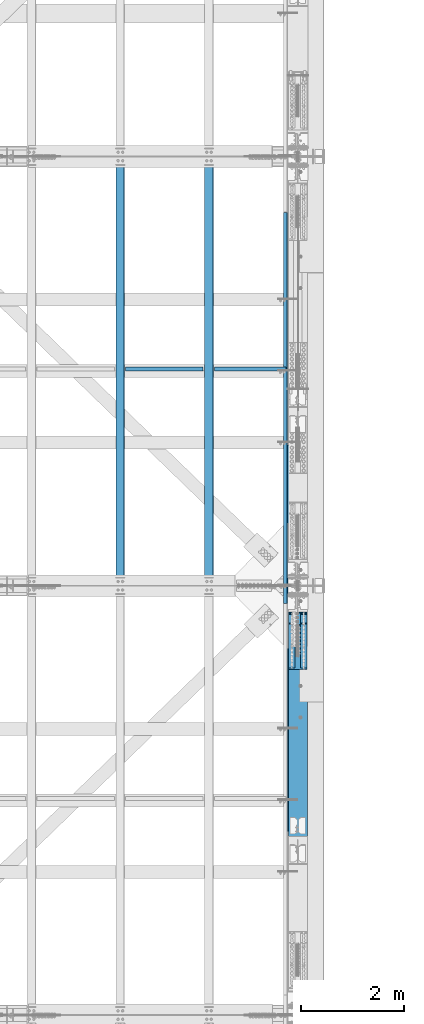
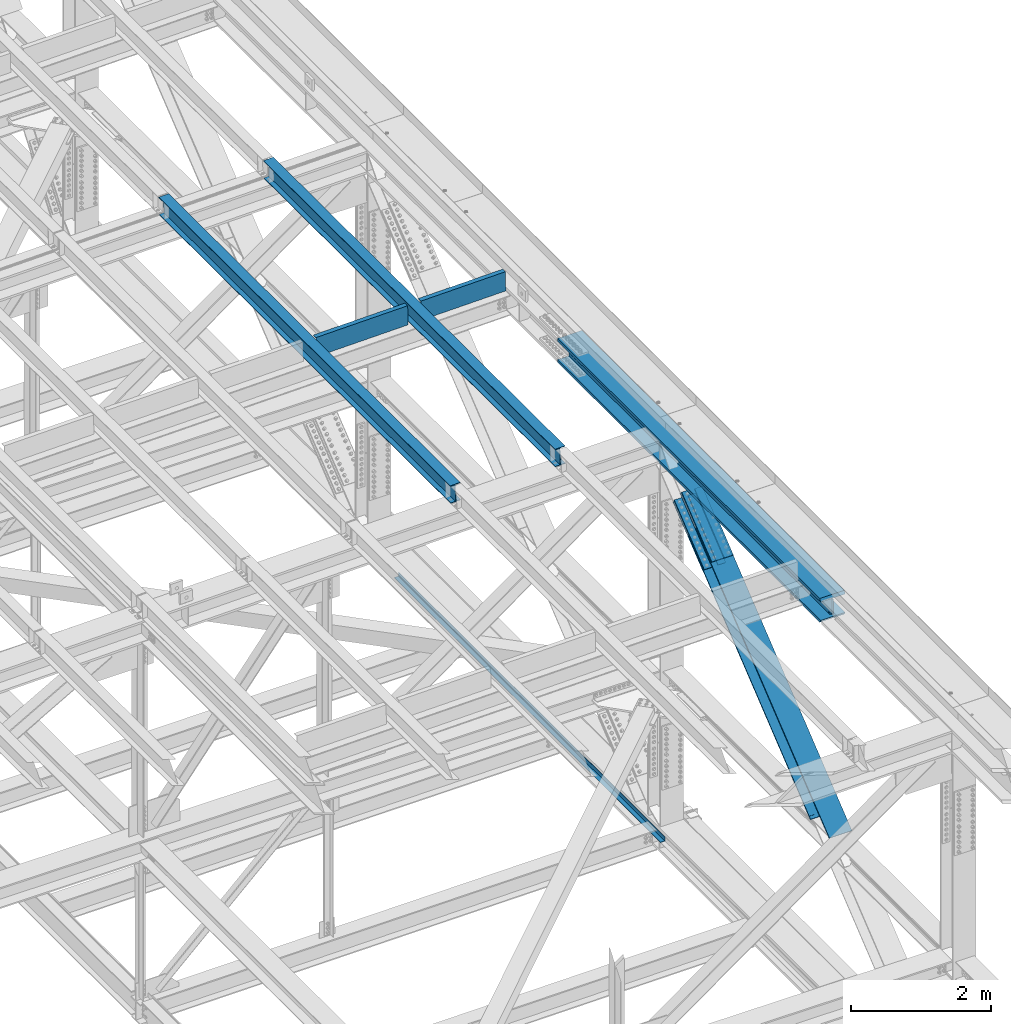
# One storey, part 1977 of 3843: 7 members, 6 beams, 7 elements without a shape of their own.
"""IFC2X3 building model written with IfcOpenShell, lengths in millimetres."""

from ifc_helpers import new_model, si_unit, frame, origin_with_axes, place, context, subcontext, project, spatial, faceted_brep, material, type_object, element, aggregate, save


model = new_model("IFC2X3")

# Units and contexts
model_context = context("Model", 3, precision=1e-05, world=origin_with_axes())
body_context = subcontext(model_context, "Body", "Model", "MODEL_VIEW")
ifc_project = project(units=[si_unit("LENGTHUNIT", "METRE", prefix="MILLI"), si_unit("AREAUNIT", "SQUARE_METRE"), si_unit("VOLUMEUNIT", "CUBIC_METRE"), si_unit("MASSUNIT", "GRAM", prefix="KILO"), si_unit("TIMEUNIT", "SECOND"), si_unit("PLANEANGLEUNIT", "RADIAN"), si_unit("SOLIDANGLEUNIT", "STERADIAN"), si_unit("THERMODYNAMICTEMPERATUREUNIT", "DEGREE_CELSIUS"), si_unit("LUMINOUSINTENSITYUNIT", "LUMEN")], contexts=[model_context])

# Site, building, storey
site_placement = place(None, origin_with_axes())
site = spatial("IfcSite", under=ifc_project, at=site_placement, CompositionType="ELEMENT")
building_placement = place(site_placement, origin_with_axes())
building = spatial("IfcBuilding", under=site, at=building_placement, Name="Undefined", CompositionType="ELEMENT")
storey_placement = place(building_placement, origin_with_axes())
storey = spatial("IfcBuildingStorey", under=building, at=storey_placement, Name="Undefined", CompositionType="ELEMENT", Elevation=0.0)

# Assembly, beam
assembly_1_placement = place(storey_placement, origin_with_axes())
assembly_1 = element("IfcElementAssembly", 1, at=assembly_1_placement, inside=storey, Name="BEAM", AssemblyPlace="NOTDEFINED", PredefinedType="RIGID_FRAME")
ifc_material_1 = material(Name="STEEL/A992")
beam_type_1 = type_object("IfcBeamType", Name="W12X26", PredefinedType="NOTDEFINED")
beam_1_placement = place(assembly_1_placement, frame((83918.3094465648, 67272.2298498019, 46651.1662682145), z_axis=(-0.0211520976180764, 0.00212019800049893, 0.999774021230195), x_axis=(-2.19999993850589e-08, 0.999997751370484, -0.00212067300078588)))
beam_1 = element("IfcBeam", 2, at=beam_1_placement, type_object=beam_type_1, material=ifc_material_1, Name="BEAM", ObjectType="W12X26", context=body_context, shape_type="Brep", body=[
    faceted_brep([(12.7037333159387, 82.5499999998865, -155.574999999728), (12.6835383837752, 82.5499999999302, -146.049999999741), (8343.90227212172, 82.5500000208849, -146.050000006406), (8343.92246705385, 82.5500000208558, -155.575000006393), (12.6799761301809, 3.17499999947904, -146.049999999777), (8343.8987098681, 3.17500002044835, -146.050000006442), (12.0606648778776, 3.17500000054133, 146.049999999763), (8343.27939861581, 3.17500002149609, 146.049999993105), (12.0642271314864, 82.5500000009924, 146.049999999799), (8343.28296086943, 82.5500000219472, 146.049999993134), (12.0440321993519, 82.5500000010361, 155.574999999786), (8343.2627659373, 82.5500000219763, 155.574999993121), (12.0366227118211, -82.5499999998865, 155.574999999699), (8343.25535644976, -82.5499999789463, 155.574999993041), (12.0568176439701, -82.5499999999156, 146.049999999719), (8343.27555138191, -82.5499999789899, 146.049999993054), (12.060379897579, -3.17499999947904, 146.049999999748), (8343.27911363552, -3.17499997852428, 146.049999993098), (12.6796911498823, -3.17500000055588, -146.049999999785), (8343.89841171799, -3.17499999977736, -146.04999998711), (12.6761288962589, -82.5500000009924, -146.049999999828), (8343.8948483616, -82.550000000876, -146.049999972267), (12.6963238284079, -82.5500000010215, -155.574999999808), (8343.91505756634, -82.5499999800668, -155.575000006465)], [[[0, 1, 2, 3]], [[1, 4, 5, 2]], [[4, 6, 7, 5]], [[6, 8, 9, 7]], [[8, 10, 11, 9]], [[10, 12, 13, 11]], [[12, 14, 15, 13]], [[14, 16, 17, 15]], [[16, 18, 19, 17]], [[18, 20, 21, 19]], [[20, 22, 23, 21]], [[22, 0, 3, 23]], [[5, 7, 9, 11, 13, 15, 17, 19, 21, 23, 3, 2]], [[22, 20, 18, 16, 14, 12, 10, 8, 6, 4, 1, 0]]]),
])
aggregate(assembly_1, [beam_1])

assembly_2_placement = place(storey_placement, origin_with_axes())
assembly_2 = element("IfcElementAssembly", 3, at=assembly_2_placement, inside=storey, Name="BEAM", AssemblyPlace="NOTDEFINED", PredefinedType="RIGID_FRAME")
beam_2_placement = place(assembly_2_placement, frame((82191.1094465142, 67272.2332875575, 46619.343604067), z_axis=(-0.0211520976140747, 0.00214229500025977, 0.99977397412548), x_axis=(-2.20000000902242e-08, 0.999997704255013, -0.00214277500054673)))
beam_2 = element("IfcBeam", 4, at=beam_2_placement, type_object=beam_type_1, material=ifc_material_1, Name="BEAM", ObjectType="W12X26", context=body_context, shape_type="Brep", body=[
    faceted_brep([(12.7037963889888, 82.550000000585, -155.57500000039), (12.68336709289, 82.5499999996246, -146.050000000039), (8343.90246569729, 82.5499999989333, -146.049999980707), (8343.92289895112, 82.5500000208558, -155.575000023666), (12.6797677313734, 3.17499999917345, -146.049999999879), (8343.89889418155, 3.1750000204629, -146.050000023519), (12.0540018845641, 3.17500000089058, 146.04999999977), (8343.27312833472, 3.17500002216548, 146.049999976145), (12.057601246066, 82.5500000013271, 146.04999999961), (8343.27672769624, 82.5500000226166, 146.049999975985), (12.0371958380274, 82.5500000013853, 155.574999999597), (8343.2563222882, 82.5500000226748, 155.574999975972), (12.0297091660614, -82.5499999995372, 155.574999999932), (8343.24883561624, -82.5499999782623, 155.574999976292), (12.0501145741, -82.5499999995955, 146.049999999945), (8343.26924102426, -82.549999978306, 146.049999976312), (12.0537139356311, -3.1749999991589, 146.049999999785), (8343.27284038581, -3.17499997786945, 146.049999976145), (12.679479782455, -3.17500000086147, -146.049999999857), (8343.89860623263, -3.17499997957202, -146.050000023497), (12.6758804209385, -82.550000001298, -146.049999999705), (8343.89500687108, -82.5499999800086, -146.050000023337), (12.6962628250476, -82.5500000003522, -155.574999999924), (8343.91541227915, -82.5499999800668, -155.575000023331)], [[[0, 1, 2, 3]], [[1, 4, 5, 2]], [[4, 6, 7, 5]], [[6, 8, 9, 7]], [[8, 10, 11, 9]], [[10, 12, 13, 11]], [[12, 14, 15, 13]], [[14, 16, 17, 15]], [[16, 18, 19, 17]], [[18, 20, 21, 19]], [[20, 22, 23, 21]], [[22, 0, 3, 23]], [[5, 7, 9, 11, 13, 15, 17, 19, 21, 23, 3, 2]], [[22, 20, 18, 16, 14, 12, 10, 8, 6, 4, 1, 0]]]),
])
aggregate(assembly_2, [beam_2])

assembly_3_placement = place(storey_placement, origin_with_axes())
assembly_3 = element("IfcElementAssembly", 5, at=assembly_3_placement, inside=storey, Name="BENT_PLATE", AssemblyPlace="NOTDEFINED", PredefinedType="RIGID_FRAME")
ifc_material_2 = material(Name="STEEL/A36")
beam_type_2 = type_object("IfcBeamType", PredefinedType="NOTDEFINED")
beam_3_placement = place(assembly_3_placement, frame((83058.4218909603, 71454.9625000037, 46442.2912357653), z_axis=(-0.999843950547446, 0.0, -0.0176656319920002), x_axis=(-0.0176656319919986, 0.0, 0.999843950547446)))
beam_3 = element("IfcBeam", 6, at=beam_3_placement, type_object=beam_type_2, material=ifc_material_2, Name="BENT_PLATE", context=body_context, shape_type="Brep", body=[
    faceted_brep([(2.38651409745216e-09, -4.76249999999709, -755.649999997448), (-2.37923813983798e-09, -4.76249999999709, 755.649999997433), (-2.37923813983798e-09, 4.76249999999709, 755.649999997433), (2.38651409745216e-09, 4.76249999999709, -755.649999997448), (327.024999945941, 4.76250000002619, 755.650000004171), (327.024999981295, 4.76250000002619, -755.650000004418), (336.549999981282, -4.76249999996799, -755.650000004447), (336.549999945928, -4.76249999996799, 755.650000004156), (327.024999958514, 71.4375000207219, 755.650000005364), (327.024999968708, 71.4375000458094, -755.650000003239), (336.549999958501, 71.4375000207219, 755.650000005349), (336.549999968687, 71.4375000458094, -755.650000003254)], [[[0, 1, 2, 3]], [[3, 2, 4, 5]], [[1, 0, 6, 7]], [[5, 4, 8, 9]], [[4, 2, 1, 7, 10, 8]], [[7, 6, 11, 10]], [[6, 0, 3, 5, 9, 11]], [[10, 11, 9, 8]]]),
])
aggregate(assembly_3, [beam_3])

assembly_4_placement = place(storey_placement, origin_with_axes())
assembly_4 = element("IfcElementAssembly", 7, at=assembly_4_placement, inside=storey, Name="BENT_PLATE", AssemblyPlace="NOTDEFINED", PredefinedType="RIGID_FRAME")
beam_4_placement = place(assembly_4_placement, frame((84728.2827694122, 71454.9625000034, 46471.6545374752), z_axis=(-0.999843928690838, 0.0, -0.0176668689945436), x_axis=(-0.0176668689945437, 0.0, 0.999843928690838)))
beam_4 = element("IfcBeam", 8, at=beam_4_placement, type_object=beam_type_2, material=ifc_material_2, Name="BENT_PLATE", context=body_context, shape_type="Brep", body=[
    faceted_brep([(2.20461515709758e-09, -4.76249999999709, -698.499999997657), (-2.19733919948339e-09, -4.76249999999709, 698.499999997628), (-2.19733919948339e-09, 4.76249999999709, 698.499999997628), (2.20461515709758e-09, 4.76249999999709, -698.499999997657), (327.025000023619, 4.76250000002619, 698.499999999302), (327.025000025125, 4.76250000002619, -698.50000000326), (336.550000025134, -4.76249999996799, -698.500000003318), (336.550000023642, -4.76249999996799, 698.499999999243), (327.025000023437, 71.4374999717184, 698.499999999287), (327.025000025285, 71.4374999714419, -698.500000003274), (336.550000023461, 71.4374999717184, 698.499999999229), (336.550000025301, 71.4374999714419, -698.500000003332)], [[[0, 1, 2, 3]], [[3, 2, 4, 5]], [[1, 0, 6, 7]], [[5, 4, 8, 9]], [[4, 2, 1, 7, 10, 8]], [[7, 6, 11, 10]], [[6, 0, 3, 5, 9, 11]], [[10, 11, 9, 8]]]),
])
aggregate(assembly_4, [beam_4])

# Assembly, beam, members
assembly_5_placement = place(storey_placement, origin_with_axes())
assembly_5 = element("IfcElementAssembly", 9, at=assembly_5_placement, inside=storey, Name="BEAM", AssemblyPlace="NOTDEFINED", PredefinedType="RIGID_FRAME")
beam_type_3 = type_object("IfcBeamType", Name="W14X257", PredefinedType="NOTDEFINED")
beam_5_placement = place(assembly_5_placement, frame((85648.8, 62483.8773032231, 46323.7310074759), z_axis=(0.0, 0.00121918199975334, 0.99999925679735), x_axis=(0.0, 0.99999925679735, -0.00121918199975249)))
beam_5 = element("IfcBeam", 10, at=beam_5_placement, type_object=beam_type_3, material=ifc_material_1, Name="BEAM", ObjectType="W14X257", context=body_context, shape_type="Brep", body=[
    faceted_brep([(4.78626660341979, 15.0812500000029, -125.806809621186), (22.248763224532, -15.0812500000029, -125.795470890975), (22.1322069293601, -15.0812500000029, 125.818679072472), (4.66970807439066, 15.0812500000029, 125.812162637063), (31.811818305905, 203.199999999997, -207.944518907141), (31.811818305905, -203.199999999997, -207.944518907141), (4.80226115437108, -203.199999999997, -160.334806021325), (4.80226115437108, -15.0812500000029, -160.334806021325), (4.80226115437108, 15.0812500000029, -160.334806021325), (4.80226115437108, 203.199999999997, -160.334806021325), (31.619153337313, -203.199999999997, 207.979925171952), (31.6191421760959, 203.199999999997, 207.980437848382), (4.65371352270449, 203.199999999997, 160.340160639891), (4.65371352270449, 15.0812500000029, 160.340160639891), (4.65371352270449, -15.0812500000029, 160.340160639891), (4.65371352270449, -203.199999999997, 160.340160639891), (99.001969869656, 15.0812500000029, -125.745633578335), (99.001969869656, -15.0812500000029, -125.745633578335), (103.853059904824, 15.0812500000029, -127.069868396189), (103.853059904824, -15.0812500000029, -127.069868396189), (107.353797789598, 15.0812500000029, -130.679786213004), (107.353797789598, -15.0812500000029, -130.679786213004), (70.8577501062537, -15.0812500000029, -160.297400892843), (70.8577501062537, 15.0812500000029, -160.297400892843), (103.329591465474, -15.0812500000029, -143.758905525203), (103.329591465474, 15.0812500000029, -143.758905525203), (107.049682716461, -15.0812500000029, -140.375476278648), (107.049682716461, 15.0812500000029, -140.375476278648), (108.528472206723, -15.0812500000029, -135.569245528299), (108.528472206723, 15.0812500000029, -135.569245528299), (753.188996009027, -203.199999999997, -207.536025889502), (753.188996009027, 203.199999999997, -207.536025889502), (1506.24719244146, 203.199999999997, -207.204355812879), (1506.24719244146, -203.199999999997, -207.204355812879), (2259.30542464805, 203.199999999997, -206.967448611089), (2259.30542464805, -203.199999999997, -206.967448611089), (3012.36368070407, 203.199999999997, -206.825304288774), (3012.36368070407, -203.199999999997, -206.825304288774), (3765.42194868479, 203.199999999997, -206.777922846879), (3765.42194868479, -203.199999999997, -206.777922846879), (4518.48021666553, 203.199999999997, -206.825304287253), (4518.48021666553, -203.199999999997, -206.825304287253), (5271.53847272154, 203.199999999997, -206.967448608062), (5271.53847272154, -203.199999999997, -206.967448608062), (6024.59670492813, 203.199999999997, -207.204355808346), (6024.59670492813, -203.199999999997, -207.204355808346), (6777.65490136057, 203.199999999997, -207.536025883455), (6777.65490136057, -203.199999999997, -207.536025883455), (7524.36043722983, 203.199999999997, -207.958861545558), (7524.36043722983, -203.199999999997, -207.958861545558), (7524.39070171332, -203.199999999997, -160.333871141935), (6777.67887338098, -203.199999999997, -159.911031916607), (6024.61468394376, -203.199999999997, -159.579359201998), (5271.55045873209, -203.199999999997, -159.342450116346), (4518.48620967082, -203.199999999997, -159.200304664329), (3765.42194868474, -203.199999999997, -159.152922846879), (3012.35768769867, -203.199999999997, -159.200304665843), (2259.2934386374, -203.199999999997, -159.34245011938), (1506.22921342575, -203.199999999997, -159.579359206524), (753.165023988513, -203.199999999997, -159.911031922653), (70.8577501062537, -203.199999999997, -160.297400892843), (70.8577501062537, 203.199999999997, -160.297400892843), (753.165023988513, 203.199999999997, -159.911031922653), (1506.22921342575, 203.199999999997, -159.579359206524), (2259.2934386374, 203.199999999997, -159.34245011938), (3012.35768769867, 203.199999999997, -159.200304665843), (3765.42194868474, 203.199999999997, -159.152922846879), (4518.48620967082, 203.199999999997, -159.200304664329), (5271.55045873209, 203.199999999997, -159.342450116346), (6024.61468394376, 203.199999999997, -159.579359201998), (6777.67887338098, 203.199999999997, -159.911031916607), (7524.39070171332, 203.199999999997, -160.333871141935), (753.165023988513, 15.0812500000029, -159.911031922653), (1506.22921342575, 15.0812500000029, -159.579359206524), (2259.2934386374, 15.0812500000029, -159.34245011938), (3012.35768769867, 15.0812500000029, -159.200304665843), (3765.42194868474, 15.0812500000029, -159.152922846879), (4518.48620967082, 15.0812500000029, -159.200304664329), (5271.55045873209, 15.0812500000029, -159.342450116346), (6024.61468394376, 15.0812500000029, -159.579359201998), (6777.67887338098, 15.0812500000029, -159.911031916607), (7524.39070171332, 15.0812500000029, -160.333871141935), (6777.84028498505, -203.199999999997, 160.763927460146), (6777.84028498505, -15.0812500000029, 160.763927460146), (7524.59448256891, -15.0812500000029, 160.341064242457), (7524.59448256891, -203.199999999997, 160.341064242457), (6024.73574264898, -203.199999999997, 161.095617947423), (6024.73574264898, -15.0812500000029, 161.095617947423), (5271.63116453652, -203.199999999997, 161.332539727831), (5271.63116453652, -15.0812500000029, 161.332539727831), (4518.5265625732, -203.199999999997, 161.474692796699), (4518.5265625732, -15.0812500000029, 161.474692796699), (3765.42194868442, -203.199999999997, 161.522077153109), (3765.42194868442, -15.0812500000029, 161.522077153109), (3012.31733479565, -203.199999999997, 161.474692795186), (3012.31733479565, -15.0812500000029, 161.474692795186), (2259.21273283232, -203.199999999997, 161.332539724812), (2259.21273283232, -15.0812500000029, 161.332539724812), (1506.10815471988, -203.199999999997, 161.09561794289), (1506.10815471988, -15.0812500000029, 161.09561794289), (753.003612383793, -203.199999999997, 160.7639274541), (753.003612383793, -15.0812500000029, 160.7639274541), (70.6906636784406, -15.0812500000029, 160.377555270432), (70.6906636784406, -203.199999999997, 160.377555270432), (752.979640363294, -203.199999999997, 208.388921420948), (752.979640363294, 203.199999999997, 208.388921420948), (1506.09017570417, -203.199999999997, 208.720614549246), (1506.09017570417, 203.199999999997, 208.720614549246), (2259.20074682168, -203.199999999997, 208.957538216513), (2259.20074682168, 203.199999999997, 208.957538216513), (3012.31134179025, -203.199999999997, 209.099692418116), (3012.31134179025, 203.199999999997, 209.099692418116), (3765.42194868436, -203.199999999997, 209.147077153109), (3765.42194868436, 203.199999999997, 209.147077153109), (4518.53255557851, -203.199999999997, 209.099692419622), (4518.53255557851, 203.199999999997, 209.099692419622), (5271.64315054708, -203.199999999997, 208.95753821954), (5271.64315054708, 203.199999999997, 208.95753821954), (6024.75372166459, -203.199999999997, 208.720614553778), (6024.75372166459, 203.199999999997, 208.720614553778), (6777.86425700548, -203.199999999997, 208.388921426995), (6777.86425700548, 203.199999999997, 208.388921426995), (7524.62474705241, -203.199999999997, 207.96605464608), (7524.62474705241, 203.199999999997, 207.96605464608), (7524.59448256891, 203.199999999997, 160.341064242457), (6777.84028498505, 203.199999999997, 160.763927460146), (6024.73574264898, 203.199999999997, 161.095617947423), (5271.63116453652, 203.199999999997, 161.332539727831), (4518.5265625732, 203.199999999997, 161.474692796699), (3765.42194868442, 203.199999999997, 161.522077153109), (3012.31733479565, 203.199999999997, 161.474692795186), (2259.21273283232, 203.199999999997, 161.332539724812), (1506.10815471988, 203.199999999997, 161.09561794289), (753.003612383793, 203.199999999997, 160.7639274541), (70.6906636784406, 203.199999999997, 160.377555270432), (6777.84028498505, 15.0812500000029, 160.763927460146), (7524.59448256891, 15.0812500000029, 160.341064242457), (6024.73574264898, 15.0812500000029, 161.095617947423), (5271.63116453652, 15.0812500000029, 161.332539727831), (4518.5265625732, 15.0812500000029, 161.474692796699), (3765.42194868442, 15.0812500000029, 161.522077153109), (3012.31733479565, 15.0812500000029, 161.474692795186), (2259.21273283232, 15.0812500000029, 161.332539724812), (1506.10815471988, 15.0812500000029, 161.09561794289), (753.003612383793, 15.0812500000029, 160.7639274541), (70.6906636784406, 15.0812500000029, 160.377555270432), (98.8702027578183, -15.0812500000029, 125.847315191349), (98.8702027578183, 15.0812500000029, 125.847315191349), (103.719936227862, -15.0812500000029, 127.176509553086), (103.719936227862, 15.0812500000029, 127.176509553086), (107.216981144185, -15.0812500000029, 130.790004984796), (107.216981144185, 15.0812500000029, 130.790004984796), (108.386655478542, -15.0812500000029, 135.68066284783), (108.386655478542, 15.0812500000029, 135.68066284783), (106.902952393793, -15.0812500000029, 140.485379024467), (106.902952393793, 15.0812500000029, 140.485379024467), (103.179403533504, -15.0812500000029, 143.865002711631), (103.179403533504, 15.0812500000029, 143.865002711631), (7524.39070171332, -15.0812500000029, -160.333871141935), (6777.67887338098, -15.0812500000029, -159.911031916607), (6024.61468394376, -15.0812500000029, -159.579359201998), (5271.55045873209, -15.0812500000029, -159.342450116346), (4518.48620967082, -15.0812500000029, -159.200304664329), (3765.42194868474, -15.0812500000029, -159.152922846879), (3012.35768769867, -15.0812500000029, -159.200304665843), (2259.2934386374, -15.0812500000029, -159.34245011938), (1506.22921342575, -15.0812500000029, -159.579359206524), (753.165023988513, -15.0812500000029, -159.911031922653)], [[[0, 1, 2, 3]], [[4, 5, 6, 7, 8, 9]], [[10, 11, 12, 13, 14, 15]], [[16, 17, 1, 0]], [[17, 16, 18, 19]], [[19, 18, 20, 21]], [[22, 23, 8, 7]], [[24, 25, 23, 22]], [[26, 27, 25, 24]], [[28, 29, 27, 26]], [[21, 20, 29, 28]], [[30, 31, 32, 33]], [[33, 32, 34, 35]], [[35, 34, 36, 37]], [[37, 36, 38, 39]], [[39, 38, 40, 41]], [[41, 40, 42, 43]], [[43, 42, 44, 45]], [[45, 44, 46, 47]], [[47, 46, 48, 49]], [[30, 33, 35, 37, 39, 41, 43, 45, 47, 49, 50, 51, 52, 53, 54, 55, 56, 57, 58, 59, 60, 6, 5]], [[31, 30, 5, 4]], [[61, 62, 63, 64, 65, 66, 67, 68, 69, 70, 71, 48, 46, 44, 42, 40, 38, 36, 34, 32, 31, 4, 9]], [[62, 72, 73, 63]], [[63, 73, 74, 64]], [[64, 74, 75, 65]], [[65, 75, 76, 66]], [[66, 76, 77, 67]], [[67, 77, 78, 68]], [[68, 78, 79, 69]], [[69, 79, 80, 70]], [[70, 80, 81, 71]], [[82, 83, 84, 85]], [[86, 87, 83, 82]], [[88, 89, 87, 86]], [[90, 91, 89, 88]], [[92, 93, 91, 90]], [[94, 95, 93, 92]], [[96, 97, 95, 94]], [[98, 99, 97, 96]], [[100, 101, 99, 98]], [[102, 101, 100, 103, 15, 14]], [[104, 105, 11, 10]], [[105, 104, 106, 107]], [[107, 106, 108, 109]], [[109, 108, 110, 111]], [[111, 110, 112, 113]], [[113, 112, 114, 115]], [[115, 114, 116, 117]], [[117, 116, 118, 119]], [[119, 118, 120, 121]], [[121, 120, 122, 123]], [[105, 107, 109, 111, 113, 115, 117, 119, 121, 123, 124, 125, 126, 127, 128, 129, 130, 131, 132, 133, 134, 12, 11]], [[135, 125, 124, 136]], [[137, 126, 125, 135]], [[138, 127, 126, 137]], [[139, 128, 127, 138]], [[140, 129, 128, 139]], [[141, 130, 129, 140]], [[142, 131, 130, 141]], [[143, 132, 131, 142]], [[144, 133, 132, 143]], [[134, 133, 144, 145, 13, 12]], [[146, 147, 3, 2]], [[148, 149, 147, 146]], [[150, 151, 149, 148]], [[152, 153, 151, 150]], [[154, 155, 153, 152]], [[156, 157, 155, 154]], [[102, 145, 157, 156]], [[14, 13, 145, 102]], [[103, 100, 98, 96, 94, 92, 90, 88, 86, 82, 85, 122, 120, 118, 116, 114, 112, 110, 108, 106, 104, 10, 15]], [[84, 158, 50, 49, 48, 71, 81, 136, 124, 123, 122, 85]], [[159, 51, 50, 158]], [[160, 52, 51, 159]], [[161, 53, 52, 160]], [[162, 54, 53, 161]], [[163, 55, 54, 162]], [[164, 56, 55, 163]], [[165, 57, 56, 164]], [[166, 58, 57, 165]], [[167, 59, 58, 166]], [[60, 59, 167, 22, 7, 6]], [[23, 72, 62, 61, 9, 8]], [[18, 16, 0, 3, 147, 149, 151, 153, 155, 157, 145, 144, 143, 142, 141, 140, 139, 138, 137, 135, 136, 81, 80, 79, 78, 77, 76, 75, 74, 73, 72, 23, 25, 27, 29, 20]], [[17, 19, 21, 28, 26, 24, 22, 167, 166, 165, 164, 163, 162, 161, 160, 159, 158, 84, 83, 87, 89, 91, 93, 95, 97, 99, 101, 102, 156, 154, 152, 150, 148, 146, 2, 1]]]),
])
ifc_material_3 = material(Name="STEEL/A572-50")
member_type_1 = type_object("IfcMemberType", PredefinedType="NOTDEFINED")
member_1_placement = place(assembly_5_placement, frame((85763.1, 65864.6813905742, 44989.4552590053), z_axis=(-1.0, 0.0, 0.0), x_axis=(0.0, 0.77717665715686, 0.629282483127005)))
member_1 = element("IfcMember", 11, at=member_1_placement, type_object=member_type_1, material=ifc_material_3, Name="PLATE", context=body_context, shape_type="Brep", body=[
    faceted_brep([(-4.36557456851006e-11, 12.7000000000116, -63.5), (-4.36557456851006e-11, 12.7000000000116, 63.5), (1104.90000001677, 12.7000000017251, 63.5), (1104.90000001677, 12.7000000017251, -63.5), (1.45519152283669e-11, -12.700000000008, 63.5), (1104.90000001682, -12.6999999982909, 63.5), (1.45519152283669e-11, -12.700000000008, -63.5), (1104.90000001682, -12.6999999982909, -63.5)], [[[0, 1, 2, 3]], [[1, 4, 5, 2]], [[4, 6, 7, 5]], [[6, 0, 3, 7]], [[5, 7, 3, 2]], [[6, 4, 1, 0]]]),
])
member_2_placement = place(assembly_5_placement, frame((85763.1, 65678.8700053605, 45218.9360964451), z_axis=(-1.0, 0.0, 0.0), x_axis=(0.0, 0.77717665715686, 0.629282483127005)))
member_2 = element("IfcMember", 12, at=member_2_placement, type_object=member_type_1, material=ifc_material_3, Name="PLATE", context=body_context, shape_type="Brep", body=[
    faceted_brep([(-4.36557456851006e-11, 12.7000000000116, -63.5), (-4.36557456851006e-11, 12.7000000000116, 63.5), (1104.90000001677, 12.7000000017251, 63.5), (1104.90000001677, 12.7000000017251, -63.5), (1.45519152283669e-11, -12.700000000008, 63.5), (1104.90000001682, -12.6999999982909, 63.5), (1.45519152283669e-11, -12.700000000008, -63.5), (1104.90000001682, -12.6999999982909, -63.5)], [[[0, 1, 2, 3]], [[1, 4, 5, 2]], [[4, 6, 7, 5]], [[6, 0, 3, 7]], [[5, 7, 3, 2]], [[6, 4, 1, 0]]]),
])
member_3_placement = place(assembly_5_placement, frame((85534.5, 65864.6813905742, 44989.4552590053), z_axis=(-1.0, 0.0, 0.0), x_axis=(0.0, 0.77717665715686, 0.629282483127005)))
member_3 = element("IfcMember", 13, at=member_3_placement, type_object=member_type_1, material=ifc_material_3, Name="PLATE", context=body_context, shape_type="Brep", body=[
    faceted_brep([(-4.36557456851006e-11, 12.7000000000116, -63.5), (-4.36557456851006e-11, 12.7000000000116, 63.5), (1104.90000001677, 12.7000000017251, 63.5), (1104.90000001677, 12.7000000017251, -63.5), (1.45519152283669e-11, -12.700000000008, 63.5), (1104.90000001682, -12.6999999982909, 63.5), (1.45519152283669e-11, -12.700000000008, -63.5), (1104.90000001682, -12.6999999982909, -63.5)], [[[0, 1, 2, 3]], [[1, 4, 5, 2]], [[4, 6, 7, 5]], [[6, 0, 3, 7]], [[5, 7, 3, 2]], [[6, 4, 1, 0]]]),
])
member_4_placement = place(assembly_5_placement, frame((85534.5, 65678.8700067443, 45218.9360947362), z_axis=(-1.0, 0.0, 0.0), x_axis=(0.0, 0.77717665715686, 0.629282483127005)))
member_4 = element("IfcMember", 14, at=member_4_placement, type_object=member_type_1, material=ifc_material_3, Name="PLATE", context=body_context, shape_type="Brep", body=[
    faceted_brep([(-4.36557456851006e-11, 12.7000000000116, -63.5), (-4.36557456851006e-11, 12.7000000000116, 63.5), (1104.90000001677, 12.7000000017251, 63.5), (1104.90000001677, 12.7000000017251, -63.5), (1.45519152283669e-11, -12.700000000008, 63.5), (1104.90000001682, -12.6999999982909, 63.5), (1.45519152283669e-11, -12.700000000008, -63.5), (1104.90000001682, -12.6999999982909, -63.5)], [[[0, 1, 2, 3]], [[1, 4, 5, 2]], [[4, 6, 7, 5]], [[6, 0, 3, 7]], [[5, 7, 3, 2]], [[6, 4, 1, 0]]]),
])
member_type_2 = type_object("IfcMemberType", PredefinedType="NOTDEFINED")
member_5_placement = place(assembly_5_placement, frame((85648.8, 66751.3554868311, 45650.2039704377), z_axis=(-1.0, 0.0, 0.0), x_axis=(0.0, -0.77717665715686, -0.629282483127005)))
member_5 = element("IfcMember", 15, at=member_5_placement, type_object=member_type_2, material=ifc_material_3, Name="PLATE", context=body_context, shape_type="Brep", body=[
    faceted_brep([(-1.45519152283669e-11, 12.7000000000025, -177.800000000003), (-1.45519152283669e-11, 12.7000000000025, 177.800000000003), (1104.90000001682, 12.7000000017051, 177.800000000003), (1104.90000001682, 12.7000000017051, -177.800000000003), (4.36557456851006e-11, -12.7000000000171, 177.800000000003), (1104.90000001686, -12.6999999983072, 177.800000000003), (4.36557456851006e-11, -12.7000000000171, -177.800000000003), (1104.90000001686, -12.6999999983072, -177.800000000003)], [[[0, 1, 2, 3]], [[1, 4, 5, 2]], [[4, 6, 7, 5]], [[6, 0, 3, 7]], [[5, 7, 3, 2]], [[6, 4, 1, 0]]]),
])
member_6_placement = place(assembly_5_placement, frame((85648.8, 66509.6008874657, 45948.7758144295), z_axis=(-1.0, 0.0, 0.0), x_axis=(0.0, -0.77717665715686, -0.629282483127005)))
member_6 = element("IfcMember", 16, at=member_6_placement, type_object=member_type_2, material=ifc_material_3, Name="PLATE", context=body_context, shape_type="Brep", body=[
    faceted_brep([(-1.45519152283669e-11, 12.7000000000025, -177.800000000003), (-1.45519152283669e-11, 12.7000000000025, 177.800000000003), (1104.90000001682, 12.7000000017051, 177.800000000003), (1104.90000001682, 12.7000000017051, -177.800000000003), (4.36557456851006e-11, -12.7000000000171, 177.800000000003), (1104.90000001686, -12.6999999983072, 177.800000000003), (4.36557456851006e-11, -12.7000000000171, -177.800000000003), (1104.90000001686, -12.6999999983072, -177.800000000003)], [[[0, 1, 2, 3]], [[1, 4, 5, 2]], [[4, 6, 7, 5]], [[6, 0, 3, 7]], [[5, 7, 3, 2]], [[6, 4, 1, 0]]]),
])
aggregate(assembly_5, [beam_5, member_1, member_2, member_3, member_4, member_5, member_6])

# Assembly, member
assembly_6_placement = place(storey_placement, origin_with_axes())
assembly_6 = element("IfcElementAssembly", 17, at=assembly_6_placement, inside=storey, Name="V. BRACE", AssemblyPlace="NOTDEFINED", PredefinedType="RIGID_FRAME")
member_type_3 = type_object("IfcMemberType", Name="W14X99", PredefinedType="NOTDEFINED")
member_7_placement = place(assembly_6_placement, frame((85648.8, 62333.682958649, 42320.3607304006), z_axis=(0.0, -0.62928248312701, 0.777176657156856), x_axis=(0.0, 0.77717665715686, 0.629282483127005)))
member_7 = element("IfcMember", 18, at=member_7_placement, type_object=member_type_3, material=ifc_material_1, Name="V. BRACE", ObjectType="W14X99", context=body_context, shape_type="Brep", body=[
    faceted_brep([(59.4385353275138, -185.737500000003, 179.387500000088), (59.4385353275138, 185.737500000003, 179.387500000088), (59.432635236386, 185.737500000003, 160.351487720913), (59.432635236386, -185.737500000003, 160.351487720913), (527.884323516832, -185.737500000003, -160.501121026562), (527.884323516832, 185.737500000003, -160.501121026562), (477.833733996667, 185.737500000003, -160.485608238738), (477.833733996667, -185.737500000003, -160.485608238738), (477.838250958259, 185.737500000003, -179.387500002038), (477.838250958259, -185.737500000003, -179.387500002038), (4969.92399040201, 185.737500000003, -179.387500018234), (4969.92399040201, -185.737500000003, -179.387500018234), (4969.92399040201, -185.737500000003, -160.337500018202), (528.010147193898, -185.737500000003, -160.337500002181), (4969.92399040201, -6.35000000000582, 160.337499982354), (4969.92399040201, -185.737500000003, 160.337499982354), (131.217588468673, -185.737500000003, 160.337499999794), (131.217588468673, -6.35000000000582, 160.337499999794), (151.357574602225, -6.35000000000582, 122.273673368592), (151.357574602225, 6.35000000000582, 122.273673368592), (106.305805437965, 6.35000000000582, 122.262907466651), (126.44250973934, -6.35000000000582, 122.267719481537), (156.855113077414, -6.35000000000582, 124.021934538428), (156.855113077414, 6.35000000000582, 124.021934538428), (160.335247415802, -6.35000000000582, 128.622805259383), (160.335247415802, 6.35000000000582, 128.622805259383), (160.521418701901, -6.35000000000582, 134.388625812982), (160.521418701901, 6.35000000000582, 134.388625812982), (157.345336866463, -6.35000000000582, 139.204417604447), (157.345336866463, 6.35000000000582, 139.204417604447), (131.18295490148, -185.737500000003, 160.365512900793), (131.18295490148, 185.737500000003, 160.365512900793), (131.217588468673, 185.737500000003, 160.337499999794), (131.217588468673, 6.35000000000582, 160.337499999794), (4969.92399040201, 185.737500000003, 160.337499982354), (4969.92399040201, 6.35000000000582, 160.337499982354), (4969.92399040201, 6.35000000000582, -160.337500018202), (4969.92399040201, 185.737500000003, -160.337500018202), (528.010147193898, 185.737500000003, -160.337500002181), (528.010147193898, 6.35000000000582, -160.337500002181), (546.812337272611, -6.35000000000582, -133.542746960255), (546.812337272611, 6.35000000000582, -133.542746960255), (544.886158346781, 6.35000000000582, -138.391946536216), (544.886158346781, -6.35000000000582, -138.391946536216), (545.894727207269, -6.35000000000582, -128.406318867721), (545.894727207269, 6.35000000000582, -128.406318867721), (542.408684158552, -6.35000000000582, -124.523999246125), (542.408684158552, 6.35000000000582, -124.523999246125), (537.400298326524, -6.35000000000582, -123.060792787892), (537.400298326524, 6.35000000000582, -123.060792787892), (427.537679104862, -6.35000000000582, -122.313997713358), (407.224991989307, 6.35000000000582, -122.175921497841), (528.010147193898, -6.35000000000582, -160.337500002181), (4969.92399040201, -6.35000000000582, -160.337500018202), (4969.92399040201, 185.737500000003, 179.387499982386), (4969.92399040201, -185.737500000003, 179.387499982386)], [[[0, 1, 2, 3]], [[4, 5, 6, 7]], [[8, 9, 7, 6]], [[10, 11, 9, 8]], [[7, 9, 11, 12, 13, 4]], [[14, 15, 16, 17]], [[18, 19, 20, 21]], [[22, 23, 19, 18]], [[24, 25, 23, 22]], [[26, 27, 25, 24]], [[28, 29, 27, 26]], [[17, 16, 30, 31, 32, 33, 29, 28]], [[34, 35, 33, 32]], [[36, 37, 38, 39]], [[40, 41, 42, 43]], [[44, 45, 41, 40]], [[46, 47, 45, 44]], [[48, 49, 47, 46]], [[49, 48, 50, 51]], [[19, 23, 25, 27, 29, 33, 35, 36, 39, 42, 41, 45, 47, 49, 51, 20]], [[50, 21, 20, 51]], [[48, 46, 44, 40, 43, 52, 53, 14, 17, 28, 26, 24, 22, 18, 21, 50]], [[12, 53, 52, 13]], [[43, 42, 39, 38, 5, 4, 13, 52]], [[37, 10, 8, 6, 5, 38]], [[36, 35, 34, 54, 55, 15, 14, 53, 12, 11, 10, 37]], [[30, 16, 15, 55, 0, 3]], [[31, 30, 3, 2]], [[54, 34, 32, 31, 2, 1]], [[55, 54, 1, 0]]]),
])
aggregate(assembly_6, [member_7])

# Assembly, beam
assembly_7_placement = place(storey_placement, origin_with_axes())
assembly_7 = element("IfcElementAssembly", 19, at=assembly_7_placement, inside=storey, Name="BENT_PLATE", AssemblyPlace="NOTDEFINED", PredefinedType="RIGID_FRAME")
beam_type_4 = type_object("IfcBeamType", PredefinedType="NOTDEFINED")
beam_6_placement = place(assembly_7_placement, frame((85369.3999999992, 70732.6500000001, 39627.174999996), z_axis=(0.0, 1.0, 0.0), x_axis=(1.0, 0.0, 0.0)))
beam_6 = element("IfcBeam", 20, at=beam_6_placement, type_object=beam_type_4, material=ifc_material_2, Name="BENT_PLATE", context=body_context, shape_type="Brep", body=[
    faceted_brep([(73.0250000000524, -7.56699591875076e-10, -3810.00000000004), (69.8500000000204, -3.17500000000291, -3806.82500000006), (0.0, -3.17500000000291, -3806.82500000006), (0.0, -7.56699591875076e-10, -3810.0), (73.0250000001397, -73.0250000000306, -3810.00000000004), (69.8500000000931, -73.0250000000015, -3806.82500000006), (0.0, 3.17500000000291, -3810.0), (0.0, 3.17500000000291, 3810.0), (76.2000000000116, 3.17500000000291, 3810.0), (76.2000000000116, 3.17500000000291, -3810.0), (0.0, -3.17500000000291, 3810.0), (69.8500000000204, -3.17500000000291, 3810.0), (69.8500000000931, -73.0250000000015, 3810.0), (76.200000000099, -73.0249999999869, 3810.0), (76.200000000099, -73.0249999999869, -3810.0)], [[[0, 1, 2, 3]], [[4, 5, 1, 0]], [[6, 7, 8, 9]], [[8, 7, 10, 11, 12, 13]], [[9, 8, 13, 14]], [[3, 6, 9, 14, 4, 0]], [[10, 7, 6, 3, 2]], [[11, 10, 2, 1]], [[12, 11, 1, 5]], [[14, 13, 12, 5, 4]]]),
])
aggregate(assembly_7, [beam_6])

save(model, "model.ifc")
